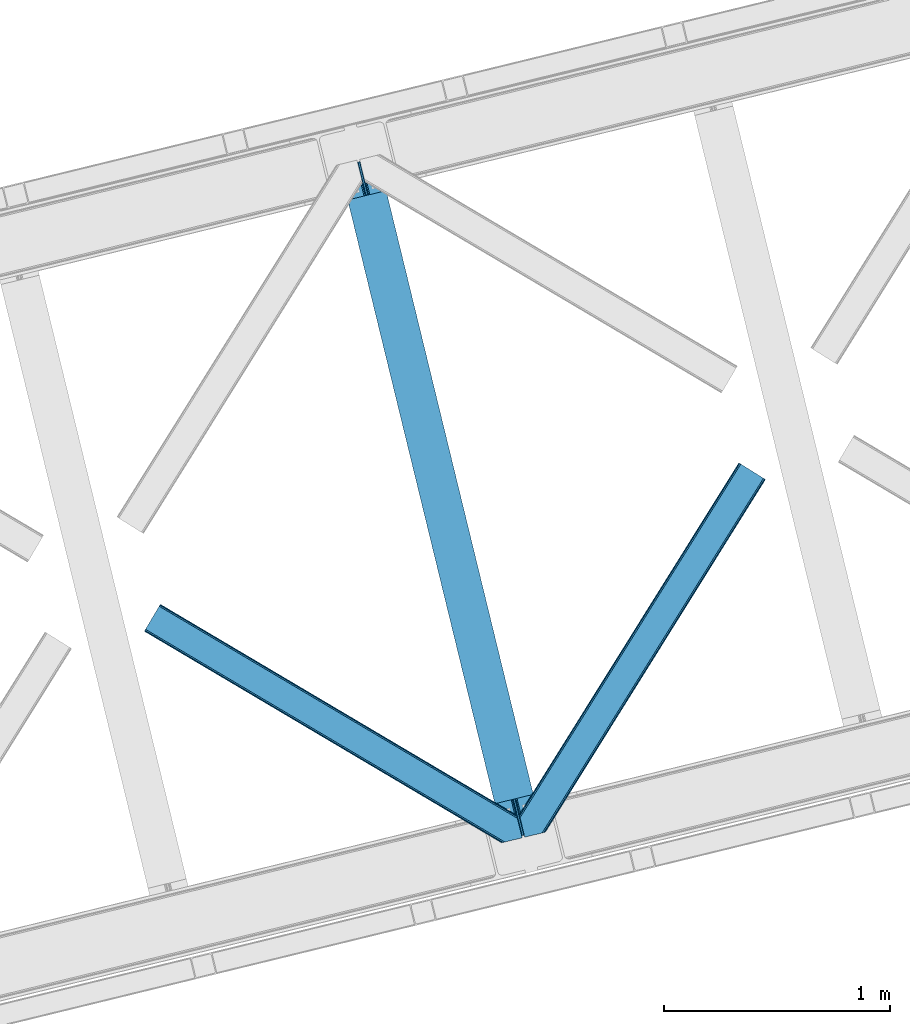
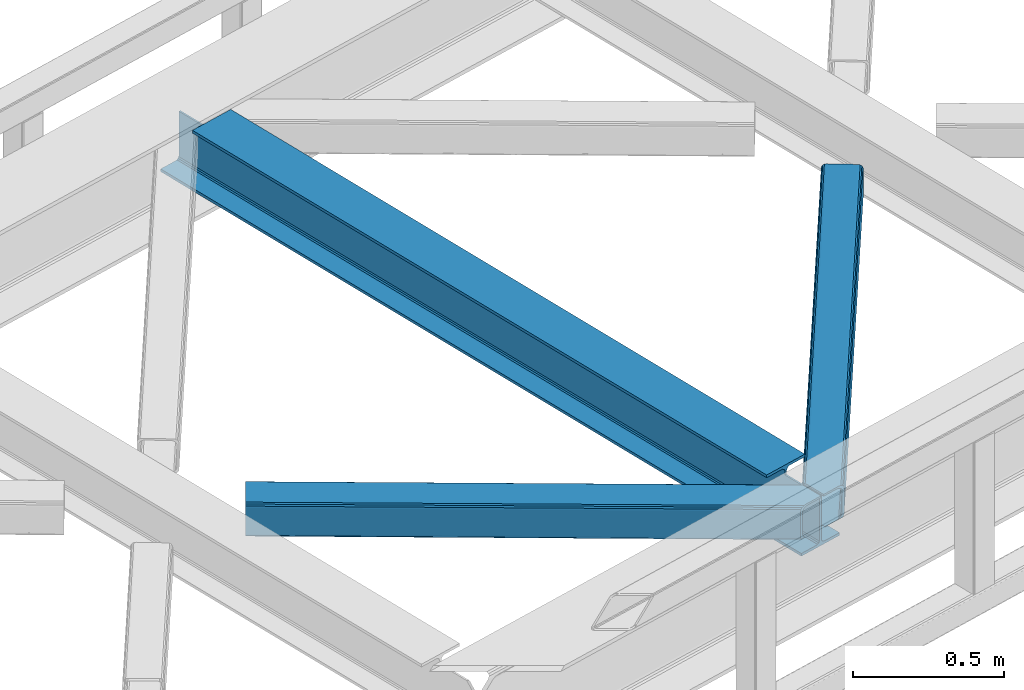
# One storey, part 68 of 93: 2 members, 1 beam.
"""IFC4 building model written with IfcOpenShell, lengths in millimetres."""

from ifc_helpers import new_model, entity, si_unit, converted_unit, derived_unit, direction, frame, origin, place, context, subcontext, project, spatial, triangles, polygons, material, type_object, element, save


model = new_model("IFC4")

# Units and contexts
model_context = context("Model", 3, precision=0.01, world=origin(), true_north=direction((6.12303176911189e-17, 1.0)))
plan_context = context("Plan", 3, precision=0.01, world=origin(), true_north=direction((6.12303176911189e-17, 1.0)))
body_context = subcontext(model_context, "Body", "Model", "MODEL_VIEW")
ifc_project = project(units=[si_unit("LENGTHUNIT", "METRE", prefix="MILLI"), si_unit("AREAUNIT", "SQUARE_METRE"), si_unit("VOLUMEUNIT", "CUBIC_METRE"), converted_unit("PLANEANGLEUNIT", "DEGREE", entity("IfcRatioMeasure", 0.0174532925199433), si_unit("PLANEANGLEUNIT", "RADIAN"), dimensions=[0, 0, 0, 0, 0, 0, 0]), si_unit("MASSUNIT", "GRAM", prefix="KILO"), derived_unit("MASSDENSITYUNIT", [(si_unit("MASSUNIT", "GRAM", prefix="KILO"), 1), (si_unit("LENGTHUNIT", "METRE"), -3)]), derived_unit("MOMENTOFINERTIAUNIT", [(si_unit("LENGTHUNIT", "METRE"), 4)]), si_unit("TIMEUNIT", "SECOND"), si_unit("FREQUENCYUNIT", "HERTZ"), si_unit("THERMODYNAMICTEMPERATUREUNIT", "DEGREE_CELSIUS"), derived_unit("THERMALTRANSMITTANCEUNIT", [(si_unit("MASSUNIT", "GRAM", prefix="KILO"), 1), (si_unit("THERMODYNAMICTEMPERATUREUNIT", "KELVIN"), -1), (si_unit("TIMEUNIT", "SECOND"), -3)]), derived_unit("VOLUMETRICFLOWRATEUNIT", [(si_unit("LENGTHUNIT", "METRE"), 3), (si_unit("TIMEUNIT", "SECOND"), -1)]), derived_unit("MASSFLOWRATEUNIT", [(si_unit("MASSUNIT", "GRAM", prefix="KILO"), 1), (si_unit("TIMEUNIT", "SECOND"), -1)]), derived_unit("ROTATIONALFREQUENCYUNIT", [(si_unit("TIMEUNIT", "SECOND"), -1)]), si_unit("ELECTRICCURRENTUNIT", "AMPERE"), si_unit("ELECTRICVOLTAGEUNIT", "VOLT"), si_unit("POWERUNIT", "WATT"), si_unit("FORCEUNIT", "NEWTON", prefix="KILO"), si_unit("ILLUMINANCEUNIT", "LUX"), si_unit("LUMINOUSFLUXUNIT", "LUMEN"), si_unit("LUMINOUSINTENSITYUNIT", "CANDELA"), derived_unit("USERDEFINED", [(si_unit("MASSUNIT", "GRAM", prefix="KILO"), -1), (si_unit("LENGTHUNIT", "METRE"), -2), (si_unit("TIMEUNIT", "SECOND"), 3), (si_unit("LUMINOUSFLUXUNIT", "LUMEN"), 1)]), derived_unit("LINEARVELOCITYUNIT", [(si_unit("LENGTHUNIT", "METRE"), 1), (si_unit("TIMEUNIT", "SECOND"), -1)]), si_unit("PRESSUREUNIT", "PASCAL"), derived_unit("USERDEFINED", [(si_unit("LENGTHUNIT", "METRE"), -2), (si_unit("MASSUNIT", "GRAM", prefix="KILO"), 1), (si_unit("TIMEUNIT", "SECOND"), -2)]), derived_unit("LINEARFORCEUNIT", [(si_unit("MASSUNIT", "GRAM", prefix="KILO"), 1), (si_unit("LENGTHUNIT", "METRE"), 1), (si_unit("TIMEUNIT", "SECOND"), -2), (si_unit("LENGTHUNIT", "METRE"), -1)]), derived_unit("PLANARFORCEUNIT", [(si_unit("MASSUNIT", "GRAM", prefix="KILO"), 1), (si_unit("LENGTHUNIT", "METRE"), 1), (si_unit("TIMEUNIT", "SECOND"), -2), (si_unit("LENGTHUNIT", "METRE"), -2)])], contexts=[model_context, plan_context])

# Site, building, storey
site_placement = place(None, origin())
site = spatial("IfcSite", under=ifc_project, at=site_placement, CompositionType="ELEMENT")
building_placement = place(site_placement, origin())
building = spatial("IfcBuilding", under=site, at=building_placement, CompositionType="ELEMENT")
storey_placement = place(building_placement, frame((0.0, 0.0, 15900.0)))
storey = spatial("IfcBuildingStorey", under=building, at=storey_placement, CompositionType="ELEMENT", Elevation=15900.0)

# Beam
ifc_material = material(Name="Metal painted (White)")
beam_type = type_object("IfcBeamType", PredefinedType="BEAM")
beam_placement = place(storey_placement, frame((-14893.7851275439, 14164.4115146696, 3441.0)))
element("IfcBeam", 1, at=beam_placement, inside=storey, type_object=beam_type, material=ifc_material, ObjectType="Steel Beam", PredefinedType="BEAM", context=body_context, shape_type="Tessellation", body=[
    polygons([(896.722476515616, 41.4445662733103, 11.000000000004), (896.722476515616, 41.4445662733103, 2.16573425859679e-12), (170.021610174763, 3022.65205668042, 2.16573425859679e-12), (170.021610174765, 3022.65205668042, 11.000000000004), (830.656936561993, 25.3403919499678, 11.000000000004), (103.956070221139, 3006.54788235708, 11.000000000004), (824.708186540698, 23.8903211957396, 12.2179274798217), (98.007320199847, 3005.09781160285, 12.2179274798217), (819.665079784591, 22.6610105689216, 15.686291501017), (92.9642134437449, 3003.86850097603, 15.686291501017), (816.295383581409, 21.8396114687119, 20.8770650821657), (89.5945172405603, 3003.04710187582, 20.8770650821657), (815.11210363173, 21.5511744621206, 27.0000000000047), (88.4112372908766, 3002.75866486923, 27.0000000000047), (81.6103728838758, 3001.1008822183, 27.0000000000047), (81.6103728838779, 3001.1008822183, 203.000000000006), (88.4112372908766, 3002.75866486923, 203.000000000006), (0.0, 2981.20749040711, 2.16573425859679e-12), (2.16573425859679e-12, 2981.20749040711, 10.9999999999997), (66.0655399536129, 2997.31166473045, 11.000000000004), (72.0142899749184, 2998.76173548469, 12.2179274798217), (77.057396731027, 2999.9910461115, 15.6862915010192), (80.4270929342029, 3000.81244521171, 20.8770650821657), (815.11210363173, 21.5511744621227, 203.000000000006), (808.311239224731, 19.8933918111897, 203.000000000006), (808.311239224727, 19.8933918111876, 27.0000000000047), (807.127959275054, 19.6049548046006, 20.8770650821657), (803.758263071878, 18.783555704393, 15.6862915010192), (798.715156315769, 17.5542450775707, 12.2179274798217), (792.766406294466, 16.1041743233447, 11.000000000004), (726.700866340851, 0.0, 10.9999999999997), (726.700866340851, 2.16573425859679e-12, 2.16573425859679e-12), (775.945201911958, 182.229070489532, 203.069792164282), (124.290390378913, 2855.5685280608, 203.000000000006), (124.513271168061, 2854.65418562638, 203.617301946336), (124.526185412587, 2854.60120565348, 217.000003693143), (775.799998669233, 182.824605273258, 217.000003676718), (775.800869277129, 182.821033832379, 204.00000679514), (769.234900758912, 180.199471824632, 203.006342981088), (769.012053092185, 181.11382383896, 203.617301946336), (768.999138847661, 181.166803811854, 217.000003693143), (117.725325591011, 2852.94340419208, 217.000003676718), (117.724454983119, 2852.94697563296, 204.00000679514), (117.580155394069, 2853.53894853353, 203.076120467494), (117.489525971919, 2853.91074540987, 203.000000000006), (776.983483393262, 183.112202246699, 223.122939328039), (780.352479801942, 183.936472070578, 228.313710402595), (785.395115205966, 185.167716295884, 231.782072735464), (791.343694076674, 186.618489150565, 232.999999602236), (857.409144942199, 202.723028934499, 232.999999283132), (857.407671605762, 202.729072911373, 243.999994005812), (687.38629070184, 161.283566114484, 243.999994827032), (687.38776403828, 161.277522137611, 233.000000104353), (753.453214903793, 177.382061921543, 232.999999785253), (759.402120032138, 178.83149638977, 231.782072861012), (764.445684539262, 180.058929212905, 228.313710479427), (767.816071449003, 180.877494870334, 223.12293937232), (116.541840866981, 2852.65580721864, 223.122939328039), (113.172844458302, 2851.83153739476, 228.313710402595), (108.13020905428, 2850.60029316945, 231.782072735464), (102.181630183566, 2849.14952031477, 232.999999602236), (36.1161793180448, 2833.04498053084, 232.999999283128), (36.1176526544823, 2833.03893655396, 243.999994005812), (206.139033558403, 2874.48444335085, 243.999994827032), (206.137560221966, 2874.49048732773, 233.000000104357), (140.072109356442, 2858.38594754379, 232.999999785253), (134.12320422811, 2856.93651307557, 231.782072861012), (129.079639720982, 2855.70908025243, 228.313710479427), (125.709252811239, 2854.890514595, 223.12293937232)], [[[1, 2, 3, 4]], [[5, 1, 4, 6]], [[7, 5, 6, 8]], [[9, 7, 8, 10]], [[11, 9, 10, 12]], [[13, 11, 12, 14]], [[15, 16, 17, 14, 12, 10, 8, 6, 4, 3, 18, 19, 20, 21, 22, 23]], [[13, 24, 25, 26, 27, 28, 29, 30, 31, 32, 2, 1, 5, 7, 9, 11]], [[2, 32, 18, 3]], [[32, 31, 19, 18]], [[31, 30, 20, 19]], [[27, 26, 15, 23]], [[28, 27, 23, 22]], [[29, 28, 22, 21]], [[30, 29, 21, 20]], [[33, 24, 13, 14, 17, 34, 35, 36, 37, 38]], [[25, 39, 40, 41, 42, 43, 44, 16, 15, 26]], [[39, 25, 24, 33]], [[45, 34, 17, 16]], [[41, 40, 38, 37, 46, 47, 48, 49, 50, 51, 52, 53, 54, 55, 56, 57]], [[42, 58, 59, 60, 61, 62, 63, 64, 65, 66, 67, 68, 69, 36, 35, 43]], [[46, 37, 36, 69]], [[47, 46, 69, 68]], [[48, 47, 68, 67]], [[49, 48, 67, 66]], [[50, 49, 66, 65]], [[51, 50, 65, 64]], [[52, 51, 64, 63]], [[53, 52, 63, 62]], [[54, 53, 62, 61]], [[55, 54, 61, 60]], [[56, 55, 60, 59]], [[57, 56, 59, 58]], [[41, 57, 58, 42]]], closed=False),
])

# Members
member_type_1 = type_object("IfcMemberType", PredefinedType="BRACE")
member_1_placement = place(storey_placement, frame((-14098.6743164063, 14177.8101837158, 3510.00011901855)))
element("IfcMember", 2, at=member_1_placement, inside=storey, type_object=member_type_1, ObjectType="Steel Horizontal Brace", PredefinedType="BRACE", context=body_context, shape_type="Tessellation", body=[
    triangles([(986.151434326172, 1647.42967529297, 0.0), (1075.22041625976, 1591.82725524902, 0.0), (119.789199829102, 259.603921508789, 0.0), (154.549868774413, 117.004486083984, 0.0), (115.90339050293, 275.545971679687, 4.52065429687718), (117.571893310547, 268.699877929686, 1.33247680664135), (158.435678100586, 101.063598632813, 4.52065429687718), (156.766012573242, 107.909692382813, 1.33247680664135), (114.825549316405, 275.743634033202, 5.52059326172093), (115.131344604491, 275.92385559082, 5.35316162109666), (158.132208251953, 99.1230194091786, 5.27525939941552), (115.440628051758, 276.108728027344, 5.18107910156323), (158.235690307616, 99.7787933349609, 5.02062377929906), (158.189181518554, 99.4822998046875, 5.13573303222802), (115.540621948241, 276.168026733398, 5.12526855468968), (115.687124633789, 275.922692871094, 4.88574829101708), (158.339172363281, 100.434567260741, 4.76482543945531), (158.032214355468, 98.4939880371094, 5.52059326172093), (1085.71744995117, 1585.27416687012, 5.12526855468968), (1080.90146484375, 1588.28096008301, 1.33247680664135), (1088.9358581543, 1583.26614990234, 10.8028289794929), (114.209307861327, 21.8533172607422, 10.8028289794929), (109.470062255859, 20.697573852538, 5.52059326172093), (1090.06485900879, 1582.56037902832, 17.5000946044929), (116.062683105469, 22.3044525146488, 17.5000946044929), (6.75075073242078, 102.619317626953, 5.52059326172093), (31.3620391845707, 1.65803833007703, 5.52059326172093), (1090.06485900879, 1582.56037902832, 122.500662231447), (116.062683105469, 22.3044525146488, 122.500662231447), (1088.9358581543, 1583.26614990234, 129.197927856447), (114.209307861327, 21.8533172607422, 129.197927856447), (1085.71744995117, 1585.27416687012, 134.874325561526), (108.936373901366, 20.5673492431633, 134.874325561526), (1080.90146484375, 1588.28096008301, 138.667117309571), (101.042669677734, 18.6430480957024, 138.667117309571), (1075.22041625976, 1591.82725524902, 139.999594116212), (91.7292846679684, 16.3734191894528, 139.999594116212), (980.470385742186, 1650.97597045899, 1.33247680664135), (975.654400634765, 1653.98276367187, 5.12526855468968), (1.68826904296839, 100.41131286621, 10.9621215820334), (972.43599243164, 1655.99194335938, 10.8028289794929), (971.306991577148, 1656.69655151367, 17.5000946044929), (0.239520263670784, 99.7787933349609, 12.5201660156272), (0.0, 100.761291503906, 17.5000946044929), (5.79266967773401, 76.9941375732415, 139.999594116212), (986.151434326172, 1647.42967529297, 139.999594116212), (24.5612915039055, 0.0, 139.999594116212), (971.306991577148, 1656.69655151367, 122.500662231447), (0.0, 100.761291503906, 122.500662231447), (980.470385742186, 1650.97597045899, 138.667117309571), (3.57652587890516, 86.088931274413, 138.667117309571), (975.654400634765, 1653.98276367187, 134.874325561526), (1.69640808105396, 93.8000885009769, 134.874325561526), (972.43599243164, 1655.99194335938, 129.197927856447), (0.44067077636646, 98.9520996093743, 129.197927856447), (29.9249176025387, 1.30805969238281, 6.99957275390625), (12.1969299316406, 74.0338531494144, 6.99957275390625), (8.9959625244137, 81.5496734619137, 8.3320495605476), (3.8869720458988, 84.8122650146488, 12.5201660156272), (1069.28589477539, 1595.53516845703, 6.99957275390625), (81.996157836913, 14.0014709472653, 6.99957275390625), (992.090606689453, 1643.72292480469, 6.99957275390625), (981.593572998047, 1650.27601318359, 12.1260040283232), (978.376327514648, 1652.28519287109, 17.8035644531265), (2.75797119140589, 89.4457031250004, 17.8035644531265), (986.410720825195, 1647.2692199707, 8.3320495605476), (977.24616394043, 1652.99096374512, 24.4996673583992), (2.31730041503943, 91.2548950195305, 24.4996673583992), (977.24616394043, 1652.99096374512, 115.501089477541), (2.31730041503943, 91.2548950195305, 115.501089477541), (4.01370849609339, 84.2936920166012, 127.87475280762), (2.75797119140589, 89.4457031250004, 122.196029663086), (5.89382629394458, 76.5825347900391, 131.667544555665), (8.10997009277344, 67.4877410888676, 133.000021362306), (24.5612915039055, 0.0, 133.000021362306), (978.376327514648, 1652.28519287109, 122.196029663086), (981.593572998047, 1650.27601318359, 127.87475280762), (986.410720825195, 1647.2692199707, 131.667544555665), (992.090606689453, 1643.72292480469, 133.000021362306), (1069.28589477539, 1595.53516845703, 133.000021362306), (81.996157836913, 14.0014709472653, 133.000021362306), (1079.78176574707, 1588.98208007813, 12.1260040283232), (1083.00017395019, 1586.97290039063, 17.8035644531265), (1084.13033752441, 1586.2671295166, 24.4996673583992), (1074.96578063965, 1591.98887329101, 8.3320495605476), (1079.78176574707, 1588.98208007813, 127.87475280762), (1084.13033752441, 1586.2671295166, 115.501089477541), (1083.00017395019, 1586.97290039063, 122.196029663086), (1074.96578063965, 1591.98887329101, 131.667544555665), (91.3095428466786, 16.2710998535149, 131.667544555665), (99.2032470703125, 18.1954010009758, 127.87475280762), (104.476181030273, 19.4802062988274, 122.196029663086), (106.329556274413, 19.9325042724613, 115.501089477541), (91.3095428466786, 16.2710998535149, 8.3320495605476), (104.476181030273, 19.4802062988274, 17.8035644531265), (99.2032470703125, 18.1954010009758, 12.1260040283232), (106.329556274413, 19.9325042724613, 24.4996673583992)], [[1, 2, 3], [4, 3, 2], [5, 3, 4], [3, 5, 6], [4, 7, 5], [7, 4, 8], [9, 10, 11], [10, 12, 13], [13, 14, 10], [12, 15, 16], [16, 17, 12], [16, 5, 7], [7, 17, 16], [17, 13, 12], [14, 11, 10], [11, 18, 9], [19, 14, 13], [13, 20, 19], [13, 17, 20], [17, 7, 20], [7, 8, 20], [21, 22, 18], [18, 19, 21], [14, 19, 11], [18, 11, 19], [22, 23, 18], [21, 24, 25], [25, 22, 21], [2, 20, 4], [8, 4, 20], [23, 26, 18], [23, 27, 26], [9, 18, 26], [24, 28, 29], [29, 25, 24], [28, 30, 29], [31, 29, 30], [30, 32, 31], [33, 31, 32], [32, 34, 33], [35, 33, 34], [34, 36, 35], [37, 35, 36], [38, 6, 5], [5, 39, 38], [39, 5, 16], [16, 15, 39], [40, 41, 9], [41, 39, 15], [15, 12, 41], [12, 9, 41], [42, 41, 40], [40, 43, 42], [43, 44, 42], [9, 26, 40], [38, 1, 6], [3, 6, 1], [36, 45, 37], [36, 46, 45], [45, 47, 37], [48, 42, 49], [44, 49, 42], [46, 50, 51], [51, 45, 46], [50, 52, 53], [53, 51, 50], [52, 54, 55], [55, 53, 52], [54, 48, 49], [49, 55, 54], [27, 56, 57], [26, 57, 58], [57, 26, 27], [59, 40, 26], [26, 58, 59], [43, 40, 59], [60, 57, 61], [60, 62, 57], [57, 56, 61], [63, 64, 65], [65, 59, 63], [66, 63, 59], [62, 66, 58], [58, 57, 62], [59, 58, 66], [64, 67, 68], [68, 65, 64], [67, 69, 70], [70, 68, 67], [71, 53, 72], [73, 74, 45], [74, 47, 45], [74, 75, 47], [51, 73, 45], [71, 51, 53], [71, 73, 51], [49, 68, 70], [55, 72, 53], [70, 72, 49], [72, 55, 49], [44, 68, 49], [43, 59, 65], [65, 68, 44], [44, 43, 65], [69, 76, 70], [72, 70, 76], [76, 77, 72], [71, 72, 77], [77, 78, 71], [73, 71, 78], [78, 79, 73], [74, 73, 79], [80, 74, 79], [74, 80, 81], [75, 74, 81], [21, 82, 83], [84, 28, 24], [21, 83, 24], [21, 19, 82], [83, 84, 24], [82, 19, 20], [60, 2, 1], [2, 85, 20], [85, 2, 60], [85, 82, 20], [30, 86, 32], [87, 28, 84], [28, 88, 30], [88, 28, 87], [30, 88, 86], [36, 80, 46], [34, 32, 86], [86, 89, 34], [89, 80, 36], [36, 34, 89], [63, 38, 39], [1, 62, 60], [1, 66, 62], [66, 1, 38], [63, 66, 38], [67, 42, 48], [41, 64, 63], [39, 41, 63], [64, 41, 42], [67, 64, 42], [50, 77, 52], [46, 80, 79], [79, 78, 46], [78, 77, 50], [50, 46, 78], [54, 52, 77], [48, 69, 67], [76, 48, 54], [48, 76, 69], [76, 54, 77], [35, 37, 90], [47, 81, 37], [81, 47, 75], [81, 90, 37], [91, 35, 90], [91, 33, 35], [33, 92, 31], [92, 33, 91], [29, 92, 93], [92, 29, 31], [61, 23, 94], [95, 96, 23], [96, 94, 23], [61, 27, 23], [27, 61, 56], [97, 95, 25], [22, 25, 95], [29, 97, 25], [97, 29, 93], [95, 23, 22], [80, 89, 90], [90, 81, 80], [89, 86, 91], [91, 90, 89], [86, 88, 92], [92, 91, 86], [88, 87, 93], [93, 92, 88], [87, 84, 97], [97, 93, 87], [84, 83, 97], [95, 97, 83], [83, 82, 95], [96, 95, 82], [82, 85, 96], [94, 96, 85], [85, 60, 94], [61, 94, 60]]),
])
member_type_2 = type_object("IfcMemberType", PredefinedType="BRACE")
member_2_placement = place(storey_placement, frame((-15757.9869873047, 14152.6640441895, 3510.00011901855)))
element("IfcMember", 3, at=member_2_placement, inside=storey, type_object=member_type_2, ObjectType="Steel Horizontal Brace", PredefinedType="BRACE", context=body_context, shape_type="Tessellation", body=[
    triangles([(1468.20573120117, 208.966314697265, 0.0), (1502.96640014648, 66.3668792724602, 0.0), (8.91457214355432, 950.879168701171, 0.0), (62.4066558837894, 1041.23179321289, 0.0), (0.679028320311772, 936.966064453125, 10.8028289794929), (1582.93826293945, 0.542990112304324, 10.8679412841811), (1580.71514282227, 0.0, 17.5000946044929), (1509.32531433106, 44.5019348144524, 9.52034912109593), (2.6114685058601, 940.230981445313, 5.12526855468968), (1507.06266174316, 49.5609283447266, 5.12526855468968), (1507.93935241699, 45.9669616699211, 8.52041015625218), (1508.99045104981, 44.856564331054, 9.27850341796875), (1508.63000793457, 45.2344482421868, 9.02037963867406), (1508.27421569824, 45.6123321533196, 8.76225585937573), (1583.38939819336, 0.652285766600471, 9.52034912109593), (1505.18370666504, 57.2709228515614, 1.33247680664135), (5.50431518554615, 945.116729736328, 1.33247680664135), (0.0, 935.820785522461, 17.5000946044929), (1580.71514282227, 0.0, 122.500662231447), (0.0, 935.820785522461, 122.500662231447), (1595.73515625, 3.66140441894458, 138.667117309571), (1605.04737854004, 5.93219604492151, 139.999594116212), (8.91457214355432, 950.879168701171, 139.999594116212), (5.50431518554615, 945.116729736328, 138.667117309571), (1587.84028930664, 1.73710327148365, 134.874325561526), (2.6114685058601, 940.230981445313, 134.874325561526), (1582.56735534668, 0.452297973632085, 129.197927856447), (0.679028320311772, 936.966064453125, 129.197927856447), (1503.01058349609, 66.1843322753903, 8.52041015625218), (1503.36637573242, 65.0402160644517, 8.90294494629052), (1503.85704345703, 64.3216552734375, 9.10758361816625), (1504.35585021973, 63.5926300048814, 9.31571044922021), (1504.84651794434, 62.8740692138672, 9.52034912109593), (1602.20104064941, 5.23805236816406, 9.52034912109593), (9.07153930664026, 951.140780639647, 8.3320495605476), (1502.85826721191, 66.8075500488267, 8.42274169922166), (6.1786926269524, 946.255032348632, 12.1260040283232), (1597.57341613769, 4.11021423339844, 12.1260040283232), (1500.64909973144, 75.8732757568359, 6.99957275390625), (12.4829589843757, 956.903219604492, 6.99957275390625), (1592.30048217773, 2.82424621581958, 17.8035644531265), (4.24625244140589, 942.990115356444, 17.8035644531265), (1590.44826965332, 2.37311096191297, 24.4996673583992), (3.56838684081958, 941.84483642578, 24.4996673583992), (1470.52303161621, 199.45991821289, 6.99957275390625), (58.8429199218754, 1035.2089050293, 6.99957275390625), (1463.23394165039, 229.366232299804, 8.52041015625218), (1468.16154785156, 209.148861694335, 8.52041015625218), (1464.10946960449, 225.772265624999, 5.12526855468968), (1468.31386413574, 208.525643920897, 8.42274169922166), (1465.98958740234, 218.061108398437, 1.33247680664135), (1590.44826965332, 2.37311096191297, 115.501089477541), (3.56838684081958, 941.84483642578, 115.501089477541), (1592.30048217773, 2.82424621581958, 122.196029663086), (4.24625244140589, 942.990115356444, 122.196029663086), (1597.57341613769, 4.11021423339844, 127.87475280762), (6.1786926269524, 946.255032348632, 127.87475280762), (1605.46712036133, 6.03451538085938, 131.667544555665), (9.07153930664026, 951.140780639647, 131.667544555665), (1614.78050537109, 8.30414428710901, 133.000021362306), (12.4829589843757, 956.903219604492, 133.000021362306), (1672.2153717041, 22.304452514647, 139.999594116212), (1672.2153717041, 22.304452514647, 133.000021362306), (1653.44791259766, 99.2985900878903, 139.999594116212), (62.4066558837894, 1041.23179321289, 139.999594116212), (1655.7652130127, 89.7921936035145, 133.000021362306), (58.8429199218754, 1035.2089050293, 133.000021362306), (1648.09591369629, 121.256552124023, 129.197927856447), (1647.6540802002, 123.065744018553, 122.500662231447), (70.642199707032, 1055.14489746094, 129.197927856447), (71.3247161865238, 1056.29250183105, 122.500662231447), (1649.35165100098, 116.104541015624, 134.874325561526), (68.714410400391, 1051.88114318848, 134.874325561526), (1651.2306060791, 108.393383789062, 138.667117309571), (65.8215637207031, 1046.99539489746, 138.667117309571), (1647.6540802002, 123.065744018553, 17.5000946044929), (71.3247161865238, 1056.29250183105, 17.5000946044929), (70.642199707032, 1055.14489746094, 10.8028289794929), (65.1471862792969, 1045.85709228516, 12.1260040283232), (67.0796264648434, 1049.12200927734, 17.8035644531265), (67.7574920654297, 1050.26845092773, 24.4996673583992), (68.714410400391, 1051.88114318848, 5.12526855468968), (65.8215637207031, 1046.99539489746, 1.33247680664135), (62.254339599609, 1040.97250671387, 8.3320495605476), (65.1471862792969, 1045.85709228516, 127.87475280762), (67.7574920654297, 1050.26845092773, 115.501089477541), (67.0796264648434, 1049.12200927734, 122.196029663086), (62.254339599609, 1040.97250671387, 131.667544555665), (1649.97138061523, 113.558184814452, 24.4996673583992), (1649.97138061523, 113.558184814452, 115.501089477541), (1653.54790649414, 98.886987304686, 131.667544555665), (1651.66895141602, 106.59814453125, 127.87475280762), (1650.41321411133, 111.750155639647, 122.196029663086), (1650.50158081055, 111.386224365233, 17.8686767578147), (1650.60971374512, 110.944390869139, 16.5199218750022), (1647.66338195801, 123.028536987304, 16.5199218750022), (1641.37423095703, 124.97144165039, 10.8702667236357), (1463.45369567871, 229.701095581055, 9.22734375000073), (1463.34091186523, 229.532501220703, 8.87387695312646), (1464.25248413086, 229.406927490234, 9.52034912109593), (1639.87199707031, 125.435366821288, 9.52034912109593), (1646.38206481934, 109.727023315429, 12.1260040283232), (1468.73128051758, 211.034793090819, 9.52034912109593), (1644.35079345703, 107.0643951416, 9.52034912109593)], [[1, 2, 3], [3, 4, 1], [5, 6, 7], [6, 5, 8], [5, 9, 10], [10, 11, 5], [12, 5, 13], [12, 8, 5], [5, 14, 13], [5, 11, 14], [8, 15, 6], [16, 10, 9], [9, 17, 16], [2, 16, 17], [17, 3, 2], [7, 18, 5], [7, 19, 20], [20, 18, 7], [21, 22, 23], [23, 24, 21], [25, 21, 24], [24, 26, 25], [27, 25, 26], [26, 28, 27], [19, 27, 28], [28, 20, 19], [11, 29, 30], [14, 30, 31], [13, 31, 32], [12, 32, 33], [33, 8, 12], [32, 12, 13], [31, 13, 14], [30, 14, 11], [34, 15, 33], [8, 33, 15], [35, 30, 29], [32, 35, 33], [35, 32, 31], [30, 35, 31], [29, 36, 35], [37, 38, 33], [33, 35, 37], [38, 34, 33], [35, 36, 39], [39, 40, 35], [41, 38, 37], [37, 42, 41], [43, 41, 42], [42, 44, 43], [39, 45, 40], [46, 40, 45], [1, 45, 39], [47, 48, 49], [48, 50, 1], [45, 1, 50], [48, 51, 49], [48, 1, 51], [2, 1, 39], [2, 39, 36], [29, 2, 36], [11, 10, 29], [29, 16, 2], [29, 10, 16], [52, 43, 44], [44, 53, 52], [54, 52, 55], [53, 55, 52], [56, 54, 57], [55, 57, 54], [58, 56, 59], [57, 59, 56], [60, 58, 61], [59, 61, 58], [56, 58, 21], [25, 56, 21], [25, 27, 54], [56, 25, 54], [54, 27, 19], [58, 22, 21], [62, 60, 63], [62, 22, 60], [58, 60, 22], [54, 19, 52], [43, 7, 41], [19, 43, 52], [7, 6, 41], [19, 7, 43], [15, 41, 6], [38, 41, 15], [34, 38, 15], [22, 64, 23], [22, 62, 64], [65, 23, 64], [66, 60, 61], [60, 66, 63], [61, 67, 66], [68, 69, 70], [71, 70, 69], [72, 68, 73], [70, 73, 68], [74, 72, 75], [73, 75, 72], [64, 74, 65], [75, 65, 74], [69, 76, 71], [77, 71, 76], [78, 79, 80], [81, 71, 77], [78, 80, 77], [78, 82, 79], [80, 81, 77], [79, 82, 83], [46, 4, 3], [4, 84, 83], [84, 4, 46], [84, 79, 83], [70, 85, 73], [86, 71, 81], [71, 87, 70], [87, 71, 86], [70, 87, 85], [65, 67, 23], [75, 73, 85], [85, 88, 75], [88, 67, 65], [65, 75, 88], [37, 17, 9], [3, 40, 46], [3, 35, 40], [35, 3, 17], [37, 35, 17], [44, 18, 20], [5, 42, 37], [9, 5, 37], [42, 5, 18], [44, 42, 18], [24, 57, 26], [23, 67, 61], [61, 59, 23], [59, 57, 24], [24, 23, 59], [28, 26, 57], [20, 53, 44], [55, 20, 28], [20, 55, 53], [55, 28, 57], [89, 90, 81], [86, 81, 90], [91, 66, 67], [67, 88, 91], [92, 91, 88], [88, 85, 92], [93, 92, 85], [85, 87, 93], [90, 93, 87], [87, 86, 90], [92, 72, 74], [66, 91, 64], [91, 92, 74], [94, 95, 96], [63, 66, 62], [64, 62, 66], [91, 74, 64], [94, 76, 89], [69, 90, 89], [89, 76, 69], [94, 96, 76], [69, 93, 90], [93, 72, 92], [72, 93, 68], [69, 68, 93], [77, 76, 97], [76, 96, 97], [98, 99, 82], [47, 82, 99], [47, 49, 82], [78, 97, 100], [100, 82, 78], [100, 98, 82], [97, 101, 100], [51, 1, 4], [4, 83, 51], [49, 51, 83], [83, 82, 49], [97, 78, 77], [80, 79, 102], [102, 95, 80], [80, 94, 89], [46, 45, 50], [103, 102, 79], [103, 104, 102], [50, 79, 84], [50, 103, 79], [50, 84, 46], [89, 81, 80], [95, 94, 80], [96, 102, 97], [102, 96, 95], [102, 101, 97], [102, 104, 101], [101, 104, 103], [103, 100, 101]]),
])

save(model, "model.ifc")
